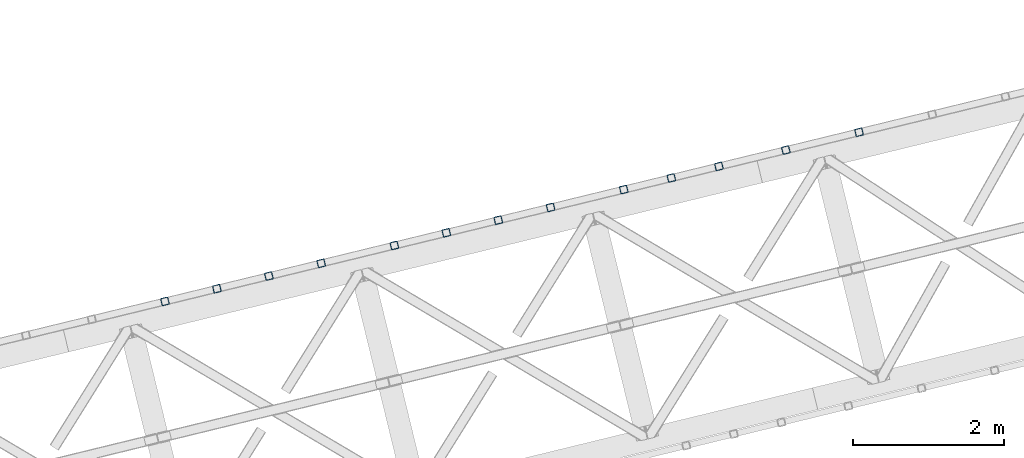
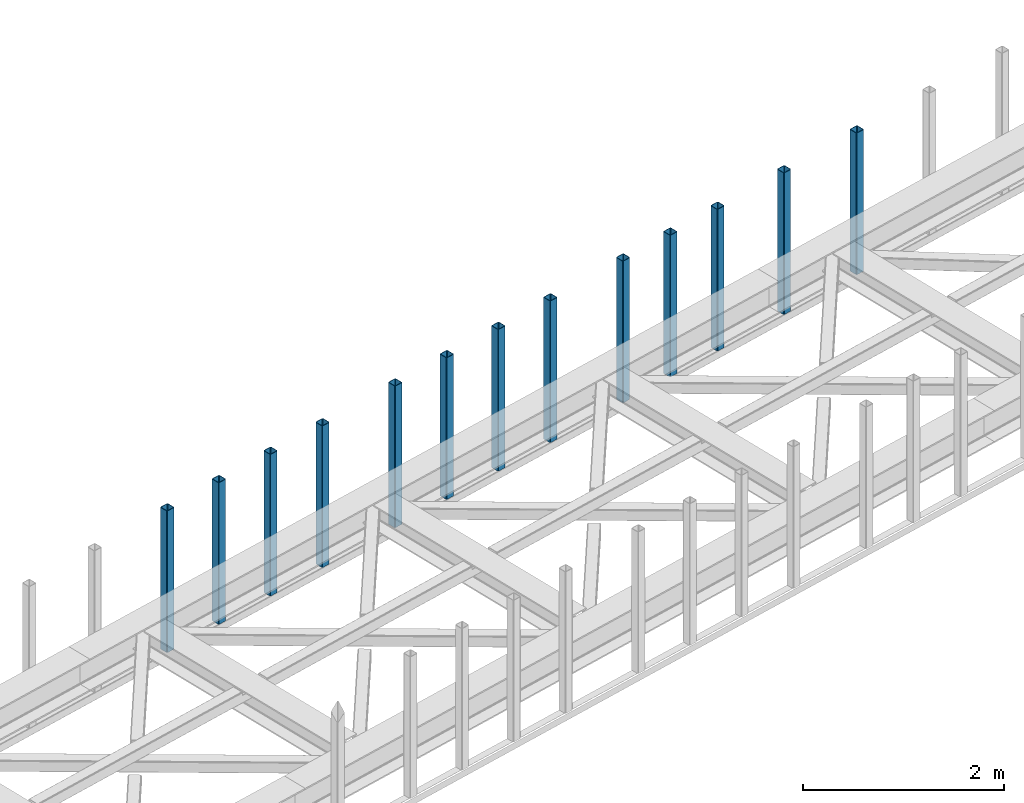
# One storey, part 10 of 66: 13 columns.
"""IFC4 building model written with IfcOpenShell, lengths in millimetres."""

from ifc_helpers import new_model, entity, si_unit, converted_unit, derived_unit, direction, frame, origin, place, context, subcontext, project, spatial, indexed_curve, outline, extrude, type_object, element, save


model = new_model("IFC4")

# Units and contexts
model_context = context("Model", 3, precision=0.01, world=origin(), true_north=direction((6.12303176911189e-17, 1.0)))
plan_context = context("Plan", 3, precision=0.01, world=origin(), true_north=direction((6.12303176911189e-17, 1.0)))
body_context = subcontext(model_context, "Body", "Model", "MODEL_VIEW")
ifc_project = project(units=[si_unit("LENGTHUNIT", "METRE", prefix="MILLI"), si_unit("AREAUNIT", "SQUARE_METRE"), si_unit("VOLUMEUNIT", "CUBIC_METRE"), converted_unit("PLANEANGLEUNIT", "DEGREE", entity("IfcRatioMeasure", 0.0174532925199433), si_unit("PLANEANGLEUNIT", "RADIAN"), dimensions=[0, 0, 0, 0, 0, 0, 0]), si_unit("MASSUNIT", "GRAM", prefix="KILO"), derived_unit("MASSDENSITYUNIT", [(si_unit("MASSUNIT", "GRAM", prefix="KILO"), 1), (si_unit("LENGTHUNIT", "METRE"), -3)]), derived_unit("MOMENTOFINERTIAUNIT", [(si_unit("LENGTHUNIT", "METRE"), 4)]), si_unit("TIMEUNIT", "SECOND"), si_unit("FREQUENCYUNIT", "HERTZ"), si_unit("THERMODYNAMICTEMPERATUREUNIT", "DEGREE_CELSIUS"), derived_unit("THERMALTRANSMITTANCEUNIT", [(si_unit("MASSUNIT", "GRAM", prefix="KILO"), 1), (si_unit("THERMODYNAMICTEMPERATUREUNIT", "KELVIN"), -1), (si_unit("TIMEUNIT", "SECOND"), -3)]), derived_unit("VOLUMETRICFLOWRATEUNIT", [(si_unit("LENGTHUNIT", "METRE"), 3), (si_unit("TIMEUNIT", "SECOND"), -1)]), derived_unit("MASSFLOWRATEUNIT", [(si_unit("MASSUNIT", "GRAM", prefix="KILO"), 1), (si_unit("TIMEUNIT", "SECOND"), -1)]), derived_unit("ROTATIONALFREQUENCYUNIT", [(si_unit("TIMEUNIT", "SECOND"), -1)]), si_unit("ELECTRICCURRENTUNIT", "AMPERE"), si_unit("ELECTRICVOLTAGEUNIT", "VOLT"), si_unit("POWERUNIT", "WATT"), si_unit("FORCEUNIT", "NEWTON", prefix="KILO"), si_unit("ILLUMINANCEUNIT", "LUX"), si_unit("LUMINOUSFLUXUNIT", "LUMEN"), si_unit("LUMINOUSINTENSITYUNIT", "CANDELA"), derived_unit("USERDEFINED", [(si_unit("MASSUNIT", "GRAM", prefix="KILO"), -1), (si_unit("LENGTHUNIT", "METRE"), -2), (si_unit("TIMEUNIT", "SECOND"), 3), (si_unit("LUMINOUSFLUXUNIT", "LUMEN"), 1)]), derived_unit("LINEARVELOCITYUNIT", [(si_unit("LENGTHUNIT", "METRE"), 1), (si_unit("TIMEUNIT", "SECOND"), -1)]), si_unit("PRESSUREUNIT", "PASCAL"), derived_unit("USERDEFINED", [(si_unit("LENGTHUNIT", "METRE"), -2), (si_unit("MASSUNIT", "GRAM", prefix="KILO"), 1), (si_unit("TIMEUNIT", "SECOND"), -2)]), derived_unit("LINEARFORCEUNIT", [(si_unit("MASSUNIT", "GRAM", prefix="KILO"), 1), (si_unit("LENGTHUNIT", "METRE"), 1), (si_unit("TIMEUNIT", "SECOND"), -2), (si_unit("LENGTHUNIT", "METRE"), -1)]), derived_unit("PLANARFORCEUNIT", [(si_unit("MASSUNIT", "GRAM", prefix="KILO"), 1), (si_unit("LENGTHUNIT", "METRE"), 1), (si_unit("TIMEUNIT", "SECOND"), -2), (si_unit("LENGTHUNIT", "METRE"), -2)])], contexts=[model_context, plan_context])

# Site, building, storey
site_placement = place(None, origin())
site = spatial("IfcSite", under=ifc_project, at=site_placement, CompositionType="ELEMENT")
building_placement = place(site_placement, origin())
building = spatial("IfcBuilding", under=site, at=building_placement, CompositionType="ELEMENT")
storey_placement = place(building_placement, frame((0.0, 0.0, 19800.0)))
storey = spatial("IfcBuildingStorey", under=building, at=storey_placement, Name="06", CompositionType="ELEMENT", Elevation=19800.0)

# Columns
column_type_1 = type_object("IfcColumnType", PredefinedType="COLUMN")
placement = place(storey_placement, origin())
element("IfcColumn", 1, at=placement, inside=storey, type_object=column_type_1, ObjectType="Steel Column", PredefinedType="COLUMN", context=body_context, shape_type="SweptSolid", body=[
    extrude(outline(indexed_curve([(29.4768951153467, -56.8428769007942), (33.3787015556676, -56.8428769007942), (36.983500665698, -55.3497202197836), (39.7424944585306, -52.5907264269563), (41.2356511395342, -48.9859273169203), (56.8428769008001, 29.4768951153439), (56.842876900801, 33.3787015556669), (55.3497202197894, 36.9835006657001), (52.5907264269631, 39.7424944585298), (48.985927316928, 41.2356511395354), (-29.4768951153342, 56.8428769008003), (-33.3787015556561, 56.8428769007984), (-36.9835006657031, 55.3497202197932), (-39.7424944585171, 52.5907264269595), (-41.2356511395314, 48.9859273169262), (-56.8428769007964, -29.476895115336), (-56.8428769007886, -33.3787015556607), (-55.3497202197934, -36.9835006656934), (-52.5907264269506, -39.7424944585237), (-48.9859273169156, -41.2356511395292), (29.4768951153467, -56.8428769007942)], self_intersect=False), holes=[indexed_curve([(-43.1065493048213, -37.3071763475937), (-46.7113484148592, -35.8140196665892), (-49.4703422076954, -33.0550258737549), (-50.9634988886935, -29.4502267637184), (-50.9634988887002, -25.5484203234015), (-37.3071763475881, 43.1065493048283), (-35.8140196665894, 46.7113484148641), (-33.0550258737608, 49.4703422076981), (-29.4502267637207, 50.9634988887041), (-25.5484203233977, 50.9634988887032), (43.1065493048309, 37.3071763475988), (46.711348414863, 35.8140196665923), (49.470342207696, 33.0550258737666), (50.9634988887067, 29.4502267637314), (50.9634988887049, 25.5484203234065), (37.3071763475917, -43.1065493048204), (35.8140196665904, -46.7113484148669), (33.0550258737586, -49.4703422076875), (29.4502267637282, -50.9634988886981), (25.5484203234112, -50.9634988886999), (-43.1065493048213, -37.3071763475937)], self_intersect=False)]), frame((-11274.84, 18249.84, 3378.0), z_axis=(0.0, 0.0, 1.0), x_axis=(0.906681479027445, 0.4218159498983, 0.0)), (0.0, 0.0, 1.0), 1720.00000000001),
])
column_type_2 = type_object("IfcColumnType", PredefinedType="COLUMN")
element("IfcColumn", 2, at=placement, inside=storey, type_object=column_type_2, ObjectType="Steel Column", PredefinedType="COLUMN", context=body_context, shape_type="SweptSolid", body=[
    extrude(outline(indexed_curve([(29.476895115345, -56.8428769008029), (33.378701555666, -56.8428769008029), (36.9835006657051, -55.3497202197941), (39.7424944585289, -52.590726426965), (41.2356511395325, -48.9859273169291), (56.8428769007984, 29.4768951153351), (56.8428769007993, 33.3787015556581), (55.3497202197965, 36.9835006656896), (52.5907264269614, 39.7424944585211), (48.9859273169264, 41.2356511395266), (-29.4768951153447, 56.8428769007933), (-33.3787015556666, 56.8428769007913), (-36.983500665696, 55.3497202197827), (-39.7424944585188, 52.5907264269508), (-41.2356511395331, 48.9859273169175), (-56.8428769007981, -29.4768951153448), (-56.8428769007903, -33.3787015556695), (-55.3497202197883, -36.983500665703), (-52.5907264269611, -39.7424944585308), (-48.9859273169261, -41.2356511395363), (29.476895115345, -56.8428769008029)], self_intersect=False), holes=[indexed_curve([(-43.106549304823, -37.3071763476025), (-46.7113484148609, -35.814019666598), (-49.4703422076892, -33.0550258737674), (-50.9634988886969, -29.450226763736), (-50.9634988886931, -25.5484203234119), (-37.3071763475889, 43.1065493048215), (-35.8140196665803, 46.7113484148527), (-33.0550258737624, 49.4703422076845), (-29.4502267637223, 50.9634988886953), (-25.5484203233994, 50.9634988886944), (43.1065493048204, 37.3071763475918), (46.7113484148622, 35.8140196665855), (49.4703422076887, 33.0550258737509), (50.9634988887041, 29.4502267637207), (50.9634988887032, 25.5484203233977), (37.3071763475961, -43.1065493048368), (35.8140196665885, -46.711348414866), (33.0550258737647, -49.4703422076999), (29.4502267637178, -50.9634988887051), (25.5484203234007, -50.963498888707), (-43.106549304823, -37.3071763476025)], self_intersect=False)]), frame((-12246.39, 18013.02, 3378.0), z_axis=(0.0, 0.0, 1.0), x_axis=(0.906681479027445, 0.4218159498983, 0.0)), (0.0, 0.0, 1.0), 1720.00000000001),
])
column_type_3 = type_object("IfcColumnType", PredefinedType="COLUMN")
element("IfcColumn", 3, at=placement, inside=storey, type_object=column_type_3, ObjectType="Steel Column", PredefinedType="COLUMN", context=body_context, shape_type="SweptSolid", body=[
    extrude(outline(indexed_curve([(29.4768951153135, -56.8428769008188), (33.3787015556354, -56.8428769008188), (36.9835006656656, -55.349720219812), (39.7424944584985, -52.5907264269832), (41.2356511395059, -48.9859273169489), (56.8428769008103, 29.4768951153055), (56.8428769008132, 33.3787015556285), (55.3497202198034, 36.9835006656625), (52.5907264269785, 39.7424944584936), (48.9859273169442, 41.2356511395009), (-29.4768951153102, 56.8428769008053), (-33.3787015556321, 56.8428769008053), (-36.9835006656798, 55.3497202198019), (-39.7424944584943, 52.5907264269716), (-41.2356511395113, 48.9859273169371), (-56.8428769008158, -29.4768951153173), (-56.8428769008099, -33.378701555642), (-55.3497202198166, -36.9835006656754), (-52.5907264269752, -39.7424944585071), (-48.9859273169409, -41.2356511395144), (29.4768951153135, -56.8428769008188)], self_intersect=False), holes=[indexed_curve([(-43.1065493048438, -37.3071763475799), (-46.71134841488, -35.8140196665717), (-49.4703422077156, -33.0550258737379), (-50.963498888712, -29.4502267637007), (-50.9634988887157, -25.5484203233818), (-37.3071763475701, 43.1065493048392), (-35.8140196665686, 46.7113484148762), (-33.0550258737387, 49.4703422077088), (-29.4502267637006, 50.9634988887119), (-25.5484203233757, 50.9634988887081), (43.106549304846, 37.3071763475693), (46.7113484148783, 35.8140196665629), (49.4703422077099, 33.0550258737358), (50.9634988887179, 29.4502267636979), (50.9634988887141, 25.548420323373), (37.3071763475664, -43.106549304847), (35.8140196665642, -46.7113484148908), (33.0550258737309, -49.47034220771), (29.450226763697, -50.9634988887198), (25.5484203233819, -50.9634988887206), (-43.1065493048438, -37.3071763475799)], self_intersect=False)]), frame((-13135.36, 17796.32, 3378.0), z_axis=(0.0, 0.0, 1.0), x_axis=(0.906681479027233, 0.421815949898756, 0.0)), (0.0, 0.0, 1.0), 1720.00000000001),
])
column_type_4 = type_object("IfcColumnType", PredefinedType="COLUMN")
element("IfcColumn", 4, at=placement, inside=storey, type_object=column_type_4, ObjectType="Steel Column", PredefinedType="COLUMN", context=body_context, shape_type="SweptSolid", body=[
    extrude(outline(indexed_curve([(29.4768951153144, -56.8428769008169), (33.3787015556363, -56.8428769008168), (36.9835006656743, -55.3497202198137), (39.7424944584907, -52.5907264269795), (41.2356511395068, -48.985927316947), (56.8428769008112, 29.4768951153075), (56.8428769008054, 33.3787015556321), (55.3497202198131, 36.9835006656627), (52.5907264269794, 39.7424944584955), (48.9859273169452, 41.2356511395029), (-29.4768951153093, 56.8428769008073), (-33.3787015556312, 56.8428769008073), (-36.9835006656701, 55.3497202198022), (-39.7424944585022, 52.5907264269753), (-41.2356511395017, 48.9859273169374), (-56.8428769008061, -29.476895115317), (-56.8428769008178, -33.3787015556383), (-55.3497202198089, -36.9835006656742), (-52.5907264269743, -39.7424944585051), (-48.98592731694, -41.2356511395124), (29.4768951153144, -56.8428769008169)], self_intersect=False), holes=[indexed_curve([(-43.1065493048428, -37.3071763475779), (-46.71134841488, -35.8140196665717), (-49.4703422077088, -33.0550258737387), (-50.9634988887127, -29.4502267637075), (-50.963498888707, -25.5484203233835), (-37.3071763475613, 43.1065493048375), (-35.8140196665579, 46.7113484148736), (-33.0550258737472, 49.4703422077008), (-29.4502267636997, 50.9634988887139), (-25.5484203233748, 50.9634988887101), (43.1065493048469, 37.3071763475713), (46.7113484148862, 35.8140196665592), (49.4703422077099, 33.0550258737358), (50.9634988887101, 29.4502267636967), (50.963498888715, 25.5484203233749), (37.3071763475673, -43.1065493048451), (35.8140196665648, -46.7113484148792), (33.0550258737388, -49.4703422077137), (29.4502267636979, -50.9634988887178), (25.5484203233828, -50.9634988887186), (-43.1065493048428, -37.3071763475779)], self_intersect=False)]), frame((-13766.87, 17642.38, 3378.0), z_axis=(0.0, 0.0, 1.0), x_axis=(0.906681479027233, 0.421815949898756, 0.0)), (0.0, 0.0, 1.0), 1720.00000000001),
])
column_type_5 = type_object("IfcColumnType", PredefinedType="COLUMN")
element("IfcColumn", 5, at=placement, inside=storey, type_object=column_type_5, ObjectType="Steel Column", PredefinedType="COLUMN", context=body_context, shape_type="SweptSolid", body=[
    extrude(outline(indexed_curve([(29.4768951153174, -56.8428769008206), (33.3787015556393, -56.8428769008206), (36.9835006656686, -55.3497202198158), (39.7424944584928, -52.5907264269853), (41.2356511395098, -48.9859273169507), (56.8428769008143, 29.4768951153037), (56.8428769008084, 33.3787015556284), (55.3497202198073, 36.9835006656606), (52.5907264269824, 39.7424944584918), (48.9859273169482, 41.2356511394991), (-29.4768951153063, 56.8428769008035), (-33.3787015556282, 56.8428769008035), (-36.9835006656671, 55.3497202197984), (-39.742494458502, 52.5907264269705), (-41.2356511395162, 48.985927316937), (-56.8428769008207, -29.4768951153174), (-56.8428769008148, -33.3787015556421), (-55.3497202198059, -36.9835006656781), (-52.5907264269713, -39.7424944585089), (-48.985927316939, -41.2356511395153), (29.4768951153174, -56.8428769008206)], self_intersect=False), holes=[indexed_curve([(-43.1065493048398, -37.3071763475817), (-46.71134841487, -35.8140196665811), (-49.4703422077058, -33.0550258737425), (-50.9634988887097, -29.4502267637113), (-50.9634988887049, -25.5484203233892), (-37.3071763475583, 43.1065493048337), (-35.8140196665549, 46.7113484148698), (-33.0550258737372, 49.4703422076914), (-29.4502267636888, 50.9634988887065), (-25.5484203233718, 50.9634988887063), (43.1065493048578, 37.3071763475638), (46.7113484148892, 35.8140196665554), (49.470342207712, 33.0550258737301), (50.963498888721, 29.4502267636893), (50.963498888718, 25.5484203233712), (37.3071763475782, -43.1065493048525), (35.8140196665669, -46.7113484148849), (33.0550258737409, -49.4703422077194), (29.4502267637087, -50.9634988887253), (25.5484203233858, -50.9634988887224), (-43.1065493048398, -37.3071763475817)], self_intersect=False)]), frame((-14398.38, 17488.45, 3378.0), z_axis=(0.0, 0.0, 1.0), x_axis=(0.906681479027233, 0.421815949898756, 0.0)), (0.0, 0.0, 1.0), 1720.00000000001),
])
column_type_6 = type_object("IfcColumnType", PredefinedType="COLUMN")
element("IfcColumn", 6, at=placement, inside=storey, type_object=column_type_6, ObjectType="Steel Column", PredefinedType="COLUMN", context=body_context, shape_type="SweptSolid", body=[
    extrude(outline(indexed_curve([(29.4768951153084, -56.8428769008093), (33.3787015556303, -56.8428769008093), (36.9835006656771, -55.3497202198078), (39.7424944585013, -52.5907264269773), (41.2356511395008, -48.9859273169394), (56.8428769008052, 29.4768951153151), (56.8428769008169, 33.3787015556363), (55.3497202198158, 36.9835006656686), (52.5907264269734, 39.7424944585031), (48.9859273169391, 41.2356511395105), (-29.4768951153065, 56.8428769008132), (-33.3787015556284, 56.8428769008132), (-36.9835006656674, 55.3497202198081), (-39.7424944584936, 52.5907264269785), (-41.2356511394989, 48.9859273169433), (-56.8428769008034, -29.4768951153111), (-56.8428769008063, -33.3787015556341), (-55.3497202198062, -36.9835006656684), (-52.5907264269716, -39.7424944584992), (-48.9859273169373, -41.2356511395065), (29.4768951153084, -56.8428769008093)], self_intersect=False), holes=[indexed_curve([(-43.1065493048498, -37.3071763475723), (-46.7113484148745, -35.8140196665599), (-49.470342207706, -33.0550258737377), (-50.9634988887109, -29.4502267637035), (-50.9634988887052, -25.5484203233795), (-37.3071763475604, 43.1065493048394), (-35.814019666556, 46.7113484148775), (-33.0550258737298, 49.4703422077023), (-29.4502267636977, 50.963498888713), (-25.5484203233817, 50.9634988887157), (43.1065493048566, 37.3071763475716), (46.711348414888, 35.8140196665631), (49.4703422077176, 33.055025873737), (50.9634988887286, 29.4502267636953), (50.9634988887247, 25.5484203233752), (37.307176347577, -43.1065493048448), (35.8140196665736, -46.7113484148809), (33.0550258737302, -49.4703422077168), (29.4502267637076, -50.9634988887176), (25.5484203233846, -50.9634988887147), (-43.1065493048498, -37.3071763475723)], self_intersect=False)]), frame((-15369.93, 17251.62, 3378.0), z_axis=(0.0, 0.0, 1.0), x_axis=(0.906681479027233, 0.421815949898756, 0.0)), (0.0, 0.0, 1.0), 1720.00000000001),
])
column_type_7 = type_object("IfcColumnType", PredefinedType="COLUMN")
element("IfcColumn", 7, at=placement, inside=storey, type_object=column_type_7, ObjectType="Steel Column", PredefinedType="COLUMN", context=body_context, shape_type="SweptSolid", body=[
    extrude(outline(indexed_curve([(29.4768951153124, -56.8428769008159), (33.3787015556343, -56.8428769008159), (36.9835006656733, -55.3497202198108), (39.7424944584907, -52.5907264269795), (41.2356511395048, -48.985927316946), (56.8428769008093, 29.4768951153084), (56.8428769008034, 33.378701555633), (55.3497202198111, 36.9835006656636), (52.5907264269774, 39.7424944584964), (48.9859273169432, 41.2356511395038), (-29.4768951153112, 56.8428769008082), (-33.3787015556332, 56.8428769008082), (-36.9835006656721, 55.3497202198031), (-39.7424944585041, 52.5907264269762), (-41.2356511395036, 48.9859273169383), (-56.8428769008081, -29.4768951153161), (-56.8428769008197, -33.3787015556374), (-55.3497202198109, -36.9835006656733), (-52.5907264269763, -39.7424944585042), (-48.985927316942, -41.2356511395115), (29.4768951153124, -56.8428769008159)], self_intersect=False), holes=[indexed_curve([(-43.1065493048457, -37.307176347579), (-46.7113484148829, -35.8140196665727), (-49.4703422077117, -33.0550258737397), (-50.9634988887156, -29.4502267637085), (-50.9634988887099, -25.5484203233845), (-37.3071763475642, 43.1065493048364), (-35.8140196665607, 46.7113484148725), (-33.05502587375, 49.4703422076998), (-29.4502267637026, 50.9634988887129), (-25.5484203233777, 50.9634988887091), (43.106549304844, 37.3071763475702), (46.7113484148833, 35.8140196665582), (49.470342207707, 33.0550258737348), (50.9634988887073, 29.4502267636957), (50.9634988887121, 25.5484203233739), (37.3071763475644, -43.1065493048461), (35.8140196665619, -46.7113484148802), (33.0550258737359, -49.4703422077147), (29.450226763695, -50.9634988887189), (25.5484203233799, -50.9634988887197), (-43.1065493048457, -37.307176347579)], self_intersect=False)]), frame((-16064.59, 17082.29, 3378.0), z_axis=(0.0, 0.0, 1.0), x_axis=(0.906681479027233, 0.421815949898756, 0.0)), (0.0, 0.0, 1.0), 1720.00000000001),
])
column_type_8 = type_object("IfcColumnType", PredefinedType="COLUMN")
element("IfcColumn", 8, at=placement, inside=storey, type_object=column_type_8, ObjectType="Steel Column", PredefinedType="COLUMN", context=body_context, shape_type="SweptSolid", body=[
    extrude(outline(indexed_curve([(29.4768951153162, -56.8428769008129), (33.3787015556381, -56.8428769008129), (36.9835006656595, -55.3497202198045), (39.7424944585004, -52.5907264269793), (41.2356511395086, -48.985927316943), (56.8428769008131, 29.4768951153114), (56.842876900816, 33.3787015556344), (55.3497202197974, 36.98350066567), (52.5907264269812, 39.7424944584995), (48.985927316947, 41.2356511395068), (-29.4768951153162, 56.8428769008129), (-33.3787015556381, 56.8428769008129), (-36.9835006656683, 55.3497202198061), (-39.7424944584945, 52.5907264269765), (-41.2356511395086, 48.985927316943), (-56.8428769008131, -29.4768951153114), (-56.8428769008072, -33.3787015556361), (-55.3497202198071, -36.9835006656703), (-52.5907264269812, -39.7424944584995), (-48.985927316947, -41.2356511395068), (29.4768951153162, -56.8428769008129)], self_intersect=False), holes=[indexed_curve([(-43.106549304841, -37.307176347574), (-46.7113484148703, -35.8140196665714), (-49.4703422077051, -33.0550258737357), (-50.9634988887109, -29.4502267637035), (-50.9634988887052, -25.5484203233795), (-37.3071763475664, 43.106549304847), (-35.8140196665551, 46.7113484148795), (-33.0550258737289, 49.4703422077042), (-29.45022676369, 50.9634988887142), (-25.548420323373, 50.963498888714), (43.1065493048478, 37.3071763475732), (46.711348414881, 35.8140196665688), (49.4703422077149, 33.0550258737311), (50.9634988887286, 29.4502267636953), (50.9634988887247, 25.5484203233752), (37.307176347583, -43.1065493048524), (35.8140196665745, -46.7113484148789), (33.0550258737406, -49.4703422077097), (29.4502267637008, -50.9634988887168), (25.5484203233758, -50.963498888713), (-43.106549304841, -37.307176347574)], self_intersect=False)]), frame((-16754.4, 16914.14, 3378.0), z_axis=(0.0, 0.0, 1.0), x_axis=(0.906681479027233, 0.421815949898756, 0.0)), (0.0, 0.0, 1.0), 1720.00000000001),
])
column_type_9 = type_object("IfcColumnType", PredefinedType="COLUMN")
element("IfcColumn", 9, at=placement, inside=storey, type_object=column_type_9, ObjectType="Steel Column", PredefinedType="COLUMN", context=body_context, shape_type="SweptSolid", body=[
    extrude(outline(indexed_curve([(29.4768951153152, -56.84287690081), (33.3787015556371, -56.84287690081), (36.9835006656751, -55.3497202198069), (39.7424944584993, -52.5907264269764), (41.2356511395076, -48.9859273169401), (56.842876900812, 29.4768951153143), (56.8428769008149, 33.3787015556372), (55.3497202198139, 36.9835006656695), (52.5907264269802, 39.7424944585023), (48.9859273169459, 41.2356511395097), (-29.4768951153173, 56.8428769008158), (-33.3787015556392, 56.8428769008158), (-36.9835006656694, 55.349720219809), (-39.7424944584955, 52.5907264269794), (-41.2356511395097, 48.9859273169459), (-56.8428769008141, -29.4768951153085), (-56.8428769008082, -33.3787015556332), (-55.3497202198081, -36.9835006656674), (-52.5907264269823, -39.7424944584966), (-48.985927316948, -41.2356511395039), (29.4768951153152, -56.84287690081)], self_intersect=False), holes=[indexed_curve([(-43.106549304843, -37.3071763475731), (-46.7113484148792, -35.8140196665648), (-49.470342207707, -33.0550258737348), (-50.9634988887129, -29.4502267637026), (-50.9634988887071, -25.5484203233786), (-37.3071763475684, 43.106549304848), (-35.8140196665571, 46.7113484148804), (-33.0550258737387, 49.4703422077088), (-29.450226763692, 50.9634988887151), (-25.5484203233749, 50.963498888715), (43.1065493048459, 37.3071763475742), (46.71134841488, 35.8140196665717), (49.4703422077041, 33.0550258737337), (50.9634988887188, 29.4502267636999), (50.9634988887157, 25.5484203233818), (37.3071763475732, -43.1065493048478), (35.8140196665647, -46.7113484148743), (33.0550258737396, -49.4703422077069), (29.4502267636988, -50.9634988887159), (25.5484203233739, -50.9634988887121), (-43.106549304843, -37.3071763475731)], self_intersect=False)]), frame((-17444.2, 16746.0, 3378.0), z_axis=(0.0, 0.0, 1.0), x_axis=(0.906681479027233, 0.421815949898756, 0.0)), (0.0, 0.0, 1.0), 1720.00000000001),
])
column_type_10 = type_object("IfcColumnType", PredefinedType="COLUMN")
element("IfcColumn", 10, at=placement, inside=storey, type_object=column_type_10, ObjectType="Steel Column", PredefinedType="COLUMN", context=body_context, shape_type="SweptSolid", body=[
    extrude(outline(indexed_curve([(29.4768951153135, -56.8428769008188), (33.3787015556354, -56.8428769008188), (36.9835006656656, -55.349720219812), (39.7424944584985, -52.5907264269832), (41.2356511395059, -48.9859273169489), (56.8428769008103, 29.4768951153055), (56.8428769008132, 33.3787015556285), (55.3497202198034, 36.9835006656625), (52.5907264269785, 39.7424944584936), (48.9859273169442, 41.2356511395009), (-29.4768951153102, 56.8428769008053), (-33.3787015556321, 56.8428769008053), (-36.9835006656798, 55.3497202198019), (-39.7424944584943, 52.5907264269716), (-41.2356511395113, 48.9859273169371), (-56.8428769008158, -29.4768951153173), (-56.8428769008099, -33.378701555642), (-55.3497202198166, -36.9835006656754), (-52.5907264269752, -39.7424944585071), (-48.9859273169409, -41.2356511395144), (29.4768951153135, -56.8428769008188)], self_intersect=False), holes=[indexed_curve([(-43.1065493048438, -37.3071763475799), (-46.7113484148721, -35.8140196665753), (-49.4703422077078, -33.0550258737416), (-50.9634988887041, -29.4502267637043), (-50.9634988887079, -25.5484203233854), (-37.3071763475622, 43.1065493048355), (-35.8140196665607, 46.7113484148725), (-33.0550258737308, 49.4703422077052), (-29.4502267636928, 50.9634988887083), (-25.5484203233757, 50.9634988887081), (43.1065493048539, 37.3071763475657), (46.7113484148862, 35.8140196665592), (49.4703422077177, 33.0550258737322), (50.9634988887257, 29.4502267636943), (50.9634988887219, 25.5484203233694), (37.3071763475743, -43.1065493048507), (35.814019666572, -46.7113484148945), (33.0550258737388, -49.4703422077136), (29.4502267637048, -50.9634988887234), (25.5484203233819, -50.9634988887206), (-43.1065493048438, -37.3071763475799)], self_intersect=False)]), frame((-18415.75, 16509.17, 3378.0), z_axis=(0.0, 0.0, 1.0), x_axis=(0.906681479027233, 0.421815949898756, 0.0)), (0.0, 0.0, 1.0), 1720.00000000001),
])
column_type_11 = type_object("IfcColumnType", PredefinedType="COLUMN")
element("IfcColumn", 11, at=placement, inside=storey, type_object=column_type_11, ObjectType="Steel Column", PredefinedType="COLUMN", context=body_context, shape_type="SweptSolid", body=[
    extrude(outline(indexed_curve([(29.4768951153094, -56.8428769008122), (33.3787015556313, -56.8428769008121), (36.9835006656703, -55.3497202198071), (39.7424944585032, -52.5907264269782), (41.2356511395018, -48.9859273169423), (56.8428769008082, 29.4768951153113), (56.8428769008179, 33.3787015556334), (55.3497202198081, 36.9835006656674), (52.5907264269744, 39.7424944585002), (48.9859273169402, 41.2356511395076), (-29.4768951153055, 56.8428769008103), (-33.3787015556274, 56.8428769008103), (-36.9835006656664, 55.3497202198052), (-39.7424944584896, 52.5907264269767), (-41.2356511395066, 48.9859273169421), (-56.8428769008111, -29.4768951153123), (-56.8428769008052, -33.378701555637), (-55.3497202198051, -36.9835006656712), (-52.5907264269705, -39.7424944585021), (-48.9859273169363, -41.2356511395094), (29.4768951153094, -56.8428769008122)], self_intersect=False), holes=[indexed_curve([(-43.1065493048478, -37.3071763475732), (-46.7113484148804, -35.8140196665571), (-49.4703422077119, -33.0550258737349), (-50.9634988887168, -29.4502267637008), (-50.963498888711, -25.5484203233768), (-37.3071763475663, 43.1065493048422), (-35.8140196665619, 46.7113484148802), (-33.0550258737357, 49.470342207705), (-29.4502267637036, 50.9634988887157), (-25.5484203233798, 50.9634988887148), (43.1065493048507, 37.3071763475743), (46.7113484148821, 35.8140196665659), (49.4703422077117, 33.0550258737397), (50.9634988887227, 29.450226763698), (50.9634988887188, 25.548420323378), (37.3071763475711, -43.1065493048421), (35.8140196665677, -46.7113484148782), (33.0550258737243, -49.4703422077141), (29.4502267637017, -50.9634988887148), (25.5484203233866, -50.9634988887156), (-43.1065493048478, -37.3071763475732)], self_intersect=False)]), frame((-19110.41, 16339.84, 3378.0), z_axis=(0.0, 0.0, 1.0), x_axis=(0.906681479027233, 0.421815949898756, 0.0)), (0.0, 0.0, 1.0), 1720.00000000001),
])
column_type_12 = type_object("IfcColumnType", PredefinedType="COLUMN")
element("IfcColumn", 12, at=placement, inside=storey, type_object=column_type_12, ObjectType="Steel Column", PredefinedType="COLUMN", context=body_context, shape_type="SweptSolid", body=[
    extrude(outline(indexed_curve([(29.4768951152999, -56.8428769008161), (33.3787015556198, -56.8428769008161), (36.9835006656602, -55.3497202198147), (39.742494458485, -52.5907264269848), (41.2356511395009, -48.9859273169497), (56.8428769008257, 29.4768951153002), (56.8428769008208, 33.3787015556248), (55.3497202198186, 36.9835006656584), (52.5907264269856, 39.7424944584918), (48.9859273169556, 41.2356511394982), (-29.4768951153059, 56.8428769008236), (-33.3787015556259, 56.8428769008236), (-36.9835006656496, 55.3497202198169), (-39.7424944584832, 52.5907264269887), (-41.2356511395021, 48.9859273169574), (-56.842876900823, -29.4768951152943), (-56.842876900818, -33.3787015556189), (-55.349720219808, -36.9835006656561), (-52.5907264269955, -39.7424944584824), (-48.9859273169616, -41.2356511394906), (29.4768951152999, -56.8428769008161)], self_intersect=False), holes=[indexed_curve([(-43.1065493048547, -37.3071763475592), (-46.7113484148799, -35.8140196665527), (-49.4703422077072, -33.0550258737171), (-50.9634988887208, -29.4502267636878), (-50.9634988887161, -25.5484203233628), (-37.3071763475593, 43.1065493048596), (-35.8140196665471, 46.7113484148868), (-33.0550258737232, 49.4703422077148), (-29.4502267636791, 50.963498888724), (-25.548420323364, 50.9634988887238), (43.1065493048536, 37.3071763475669), (46.7113484148854, 35.8140196665645), (49.4703422077293, 33.0550258737236), (50.9634988887305, 29.450226763688), (50.9634988887276, 25.548420323367), (37.3071763475699, -43.1065493048573), (35.8140196665616, -46.7113484148864), (33.0550258737338, -49.4703422077125), (29.4502267636819, -50.9634988887181), (25.5484203233589, -50.9634988887143), (-43.1065493048547, -37.3071763475592)], self_intersect=False)]), frame((-19800.21, 16171.69, 3378.0), z_axis=(0.0, 0.0, 1.0), x_axis=(0.906681479027134, 0.421815949898968, 0.0)), (0.0, 0.0, 1.0), 1720.00000000001),
])
column_type_13 = type_object("IfcColumnType", PredefinedType="COLUMN")
element("IfcColumn", 13, at=placement, inside=storey, type_object=column_type_13, ObjectType="Steel Column", PredefinedType="COLUMN", context=body_context, shape_type="SweptSolid", body=[
    extrude(outline(indexed_curve([(29.476895115302, -56.8428769008218), (33.3787015556219, -56.8428769008218), (36.9835006656544, -55.3497202198168), (39.7424944584793, -52.5907264269869), (41.2356511394982, -48.9859273169556), (56.8428769008191, 29.4768951152961), (56.8428769008141, 33.3787015556208), (55.349720219812, 36.9835006656543), (52.5907264269916, 39.7424944584843), (48.9859273169577, 41.2356511394924), (-29.476895115295, 56.8428769008162), (-33.378701555615, 56.8428769008162), (-36.9835006656563, 55.3497202198129), (-39.742494458489, 52.5907264269866), (-41.2356511395049, 48.9859273169515), (-56.8428769008297, -29.4768951152983), (-56.8428769008247, -33.378701555623), (-55.3497202198147, -36.9835006656602), (-52.5907264269847, -39.7424944584899), (-48.9859273169507, -41.2356511394981), (29.476895115302, -56.8428769008218)], self_intersect=False), holes=[indexed_curve([(-43.1065493048536, -37.3071763475669), (-46.7113484148884, -35.8140196665607), (-49.4703422077166, -33.0550258737271), (-50.9634988887196, -29.4502267636955), (-50.9634988887149, -25.5484203233706), (-37.3071763475512, 43.1065493048462), (-35.8140196665489, 46.7113484148829), (-33.0550258737395, 49.4703422077104), (-29.4502267636858, 50.9634988887199), (-25.5484203233628, 50.9634988887161), (43.1065493048557, 37.3071763475612), (46.7113484148926, 35.8140196665492), (49.4703422077157, 33.0550258737251), (50.963498888719, 29.4502267636838), (50.963498888721, 25.548420323363), (37.3071763475572, -43.1065493048538), (35.8140196665519, -46.7113484148867), (33.0550258737253, -49.4703422077205), (29.450226763684, -50.9634988887238), (25.5484203233689, -50.9634988887237), (-43.1065493048536, -37.3071763475669)], self_intersect=False)]), frame((-20490.01, 16003.55, 3378.0), z_axis=(0.0, 0.0, 1.0), x_axis=(0.906681479027134, 0.421815949898968, 0.0)), (0.0, 0.0, 1.0), 1720.00000000001),
])

save(model, "model.ifc")
